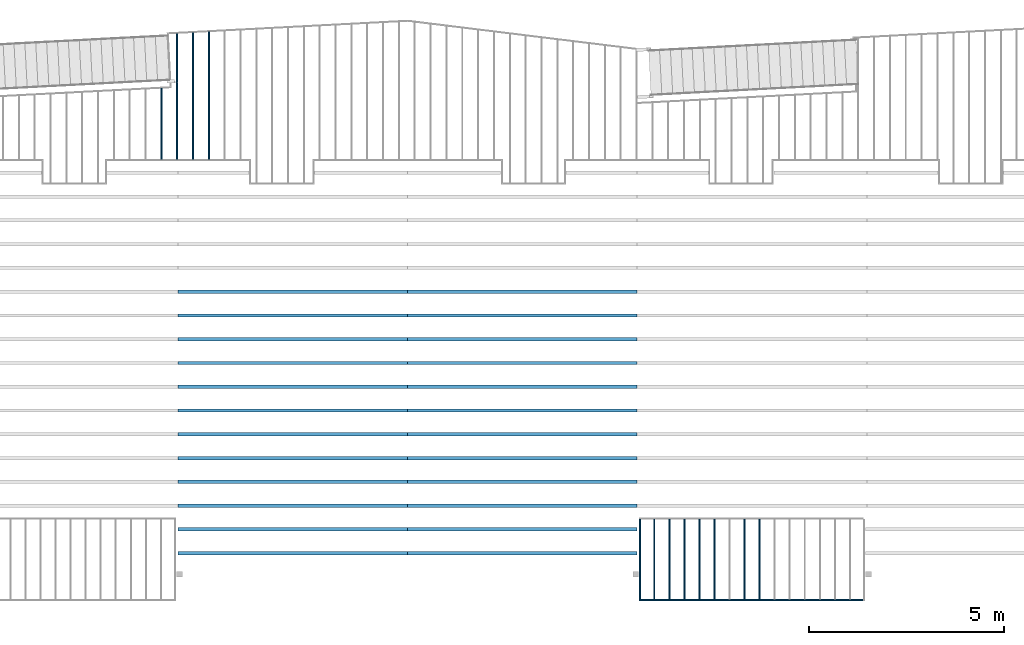
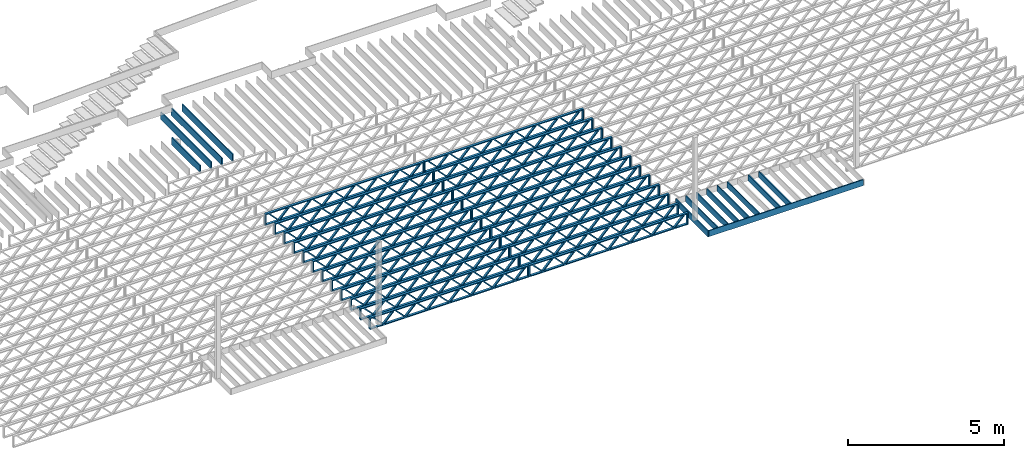
# One storey, part 6 of 23: 37 beams, 4 elements without a shape of their own.
"""IFC4 building model written with IfcOpenShell, lengths in feet."""

from ifc_helpers import new_model, entity, si_unit, converted_unit, derived_unit, direction, frame, frame_2d, origin, origin_2d_with_axis, place, context, subcontext, project, spatial, rectangle, extrude, source, transform, mapped, material, material_profile, profile_set, profile_usage, type_object, type_shapes, element, aggregate, save


model = new_model("IFC4")

# Units and contexts
model_context = context("Model", 3, precision=0.0001, world=origin(), true_north=direction((6.12303176911189e-17, 1.0)))
body_context = subcontext(model_context, "Body", "Model", "MODEL_VIEW")
ifc_project = project(units=[converted_unit("LENGTHUNIT", "FOOT", entity("IfcRatioMeasure", 0.3048), si_unit("LENGTHUNIT", "METRE"), dimensions=[1, 0, 0, 0, 0, 0, 0]), converted_unit("AREAUNIT", "SQUARE FOOT", entity("IfcRatioMeasure", 0.09290304), si_unit("AREAUNIT", "SQUARE_METRE"), dimensions=[2, 0, 0, 0, 0, 0, 0]), converted_unit("VOLUMEUNIT", "CUBIC FOOT", entity("IfcRatioMeasure", 0.028316846592), si_unit("VOLUMEUNIT", "CUBIC_METRE"), dimensions=[3, 0, 0, 0, 0, 0, 0]), converted_unit("PLANEANGLEUNIT", "DEGREE", entity("IfcRatioMeasure", 0.0174532925199433), si_unit("PLANEANGLEUNIT", "RADIAN"), dimensions=[0, 0, 0, 0, 0, 0, 0]), si_unit("MASSUNIT", "GRAM", prefix="KILO"), derived_unit("MASSDENSITYUNIT", [(si_unit("MASSUNIT", "GRAM", prefix="KILO"), 1), (si_unit("LENGTHUNIT", "METRE"), -3)]), derived_unit("MOMENTOFINERTIAUNIT", [(si_unit("LENGTHUNIT", "METRE"), 4)]), si_unit("TIMEUNIT", "SECOND"), si_unit("FREQUENCYUNIT", "HERTZ"), si_unit("THERMODYNAMICTEMPERATUREUNIT", "DEGREE_CELSIUS"), derived_unit("THERMALTRANSMITTANCEUNIT", [(si_unit("MASSUNIT", "GRAM", prefix="KILO"), 1), (si_unit("THERMODYNAMICTEMPERATUREUNIT", "KELVIN"), -1), (si_unit("TIMEUNIT", "SECOND"), -3)]), derived_unit("VOLUMETRICFLOWRATEUNIT", [(si_unit("LENGTHUNIT", "METRE"), 3), (si_unit("TIMEUNIT", "SECOND"), -1)]), si_unit("ELECTRICCURRENTUNIT", "AMPERE"), si_unit("ELECTRICVOLTAGEUNIT", "VOLT"), si_unit("POWERUNIT", "WATT"), si_unit("FORCEUNIT", "NEWTON"), si_unit("ILLUMINANCEUNIT", "LUX"), si_unit("LUMINOUSFLUXUNIT", "LUMEN"), si_unit("LUMINOUSINTENSITYUNIT", "CANDELA"), derived_unit("USERDEFINED", [(si_unit("MASSUNIT", "GRAM", prefix="KILO"), -1), (si_unit("LENGTHUNIT", "METRE"), -2), (si_unit("TIMEUNIT", "SECOND"), 3), (si_unit("LUMINOUSFLUXUNIT", "LUMEN"), 1)]), derived_unit("LINEARVELOCITYUNIT", [(si_unit("LENGTHUNIT", "METRE"), 1), (si_unit("TIMEUNIT", "SECOND"), -1)]), si_unit("PRESSUREUNIT", "PASCAL"), derived_unit("USERDEFINED", [(si_unit("LENGTHUNIT", "METRE"), -2), (si_unit("MASSUNIT", "GRAM", prefix="KILO"), 1), (si_unit("TIMEUNIT", "SECOND"), -2)]), derived_unit("LINEARFORCEUNIT", [(si_unit("MASSUNIT", "GRAM", prefix="KILO"), 1), (si_unit("LENGTHUNIT", "METRE"), 1), (si_unit("TIMEUNIT", "SECOND"), -2), (si_unit("LENGTHUNIT", "METRE"), -1)]), derived_unit("PLANARFORCEUNIT", [(si_unit("MASSUNIT", "GRAM", prefix="KILO"), 1), (si_unit("LENGTHUNIT", "METRE"), 1), (si_unit("TIMEUNIT", "SECOND"), -2), (si_unit("LENGTHUNIT", "METRE"), -2)])], contexts=[model_context])

# Site, building, storey
site_placement = place(None, origin())
site = spatial("IfcSite", under=ifc_project, at=site_placement, CompositionType="ELEMENT")
building_placement = place(site_placement, origin())
building = spatial("IfcBuilding", under=site, at=building_placement, CompositionType="ELEMENT")
storey_placement = place(building_placement, frame((0.0, 0.0, 10.8020833333333)))
storey = spatial("IfcBuildingStorey", under=building, at=storey_placement, Name="2ND FLOOR", CompositionType="ELEMENT", Elevation=10.8020833333333)

# Assembly, beams
assembly_1_placement = place(storey_placement, origin())
assembly_1 = element("IfcElementAssembly", 1, at=assembly_1_placement, inside=storey, Name="Structural Beam System:Structural Framing System", ObjectType="Structural Beam System:Structural Framing System", AssemblyPlace="NOTDEFINED", PredefinedType="BEAM_GRID")
ifc_material_1 = material(Category="Materials")
ifc_material_profile_1 = material_profile(ifc_material_1, rectangle(XDim=0.770833333333333, YDim=0.124999999999994, at=frame_2d((-5.55111512312578e-17, 0.0), x_axis=(1.0, 0.0))))
ifc_profile_set_1 = profile_set([ifc_material_profile_1])
ifc_profile_usage_1 = profile_usage(ifc_profile_set_1, cardinal=8)
beam_type_1 = type_object("IfcBeamType", PredefinedType="BEAM", material=ifc_profile_set_1)
shared_shape_1 = source(origin(), body_context, "Body", "SweptSolid", [
    extrude(rectangle(XDim=0.770833333333333, YDim=0.124999999999994, at=frame_2d((-5.55111512312578e-17, 0.0), x_axis=(1.0, 0.0))), frame((-3.35416666666737, 0.0, 0.0), z_axis=(1.0, 0.0, 0.0), x_axis=(0.0, 0.0, -1.0)), (0.0, 0.0, 1.0), 6.70833333333462),
])
type_shapes(beam_type_1, [shared_shape_1])
beam_1_placement = place(assembly_1_placement, frame((-173.43642510598, 925.341101549317, -0.645833333333471), z_axis=(0.0, 0.0, 1.0), x_axis=(0.0, 1.0, 0.0)))
beam_1 = element("IfcBeam", 2, at=beam_1_placement, type_object=beam_type_1, material=ifc_profile_usage_1, PredefinedType="BEAM", context=body_context, shape_type="MappedRepresentation", body=[
    mapped(shared_shape_1, transform((0.0, 0.0, 0.0), scale=1.0)),
])
ifc_profile_usage_2 = profile_usage(ifc_profile_set_1, cardinal=8)
beam_2_placement = place(assembly_1_placement, frame((-174.703308786538, 925.341101549318, -0.645833333333433), z_axis=(0.0, 0.0, 1.0), x_axis=(0.0, 1.0, 0.0)))
beam_2 = element("IfcBeam", 3, at=beam_2_placement, type_object=beam_type_1, material=ifc_profile_usage_2, PredefinedType="BEAM", context=body_context, shape_type="MappedRepresentation", body=[
    mapped(shared_shape_1, transform((0.0, 0.0, 0.0), scale=1.0)),
])
ifc_profile_usage_3 = profile_usage(ifc_profile_set_1, cardinal=8)
beam_3_placement = place(assembly_1_placement, frame((-177.237076147655, 925.341101549318, -0.645833333333471), z_axis=(0.0, 0.0, 1.0), x_axis=(0.0, 1.0, 0.0)))
beam_3 = element("IfcBeam", 4, at=beam_3_placement, type_object=beam_type_1, material=ifc_profile_usage_3, PredefinedType="BEAM", context=body_context, shape_type="MappedRepresentation", body=[
    mapped(shared_shape_1, transform((0.0, 0.0, 0.0), scale=1.0)),
])
ifc_profile_usage_4 = profile_usage(ifc_profile_set_1, cardinal=8)
beam_4_placement = place(assembly_1_placement, frame((-178.503959828213, 925.341101549318, -0.645833333333471), z_axis=(0.0, 0.0, 1.0), x_axis=(0.0, 1.0, 0.0)))
beam_4 = element("IfcBeam", 5, at=beam_4_placement, type_object=beam_type_1, material=ifc_profile_usage_4, PredefinedType="BEAM", context=body_context, shape_type="MappedRepresentation", body=[
    mapped(shared_shape_1, transform((0.0, 0.0, 0.0), scale=1.0)),
])
ifc_profile_usage_5 = profile_usage(ifc_profile_set_1, cardinal=8)
beam_5_placement = place(assembly_1_placement, frame((-179.770843508771, 925.341101549318, -0.645833333333471), z_axis=(0.0, 0.0, 1.0), x_axis=(0.0, 1.0, 0.0)))
beam_5 = element("IfcBeam", 6, at=beam_5_placement, type_object=beam_type_1, material=ifc_profile_usage_5, PredefinedType="BEAM", context=body_context, shape_type="MappedRepresentation", body=[
    mapped(shared_shape_1, transform((0.0, 0.0, 0.0), scale=1.0)),
])
ifc_profile_usage_6 = profile_usage(ifc_profile_set_1, cardinal=8)
beam_6_placement = place(assembly_1_placement, frame((-181.03772718933, 925.341101549318, -0.645833333333471), z_axis=(0.0, 0.0, 1.0), x_axis=(0.0, 1.0, 0.0)))
beam_6 = element("IfcBeam", 7, at=beam_6_placement, type_object=beam_type_1, material=ifc_profile_usage_6, PredefinedType="BEAM", context=body_context, shape_type="MappedRepresentation", body=[
    mapped(shared_shape_1, transform((0.0, 0.0, 0.0), scale=1.0)),
])
ifc_profile_usage_7 = profile_usage(ifc_profile_set_1, cardinal=8)
beam_7_placement = place(assembly_1_placement, frame((-182.304610869888, 925.341101549319, -0.645833333333471), z_axis=(0.0, 0.0, 1.0), x_axis=(0.0, 1.0, 0.0)))
beam_7 = element("IfcBeam", 8, at=beam_7_placement, type_object=beam_type_1, material=ifc_profile_usage_7, PredefinedType="BEAM", context=body_context, shape_type="MappedRepresentation", body=[
    mapped(shared_shape_1, transform((0.0, 0.0, 0.0), scale=1.0)),
])
aggregate(assembly_1, [beam_1, beam_2, beam_3, beam_4, beam_5, beam_6, beam_7])

assembly_2_placement = place(storey_placement, origin())
assembly_2 = element("IfcElementAssembly", 9, at=assembly_2_placement, inside=storey, Name="Structural Beam System:Structural Framing System", ObjectType="Structural Beam System:Structural Framing System", AssemblyPlace="NOTDEFINED", PredefinedType="BEAM_GRID")
ifc_material_2 = material(Name="WOOD TRUSS", Category="Materials")
ifc_material_profile_2 = material_profile(ifc_material_2, rectangle(XDim=1.73473973950632, YDim=0.125, at=frame_2d((-1.11022302462516e-16, 8.32667268468867e-17), x_axis=(1.0, 0.0))))
ifc_material_profile_3 = material_profile(ifc_material_2, rectangle(XDim=1.73473973950633, YDim=0.125, at=frame_2d((-1.11022302462516e-16, 8.32667268468867e-17), x_axis=(1.0, 0.0))))
ifc_material_profile_4 = material_profile(ifc_material_2, rectangle(XDim=1.73473973950632, YDim=0.125, at=frame_2d((-5.55111512312578e-17, 1.38777878078145e-16), x_axis=(1.0, 0.0))))
ifc_material_profile_5 = material_profile(ifc_material_2, rectangle(XDim=1.73473973950633, YDim=0.125, at=frame_2d((-1.11022302462516e-16, 8.32667268468867e-17), x_axis=(1.0, 0.0))))
ifc_material_profile_6 = material_profile(ifc_material_2, rectangle(XDim=1.73473973950632, YDim=0.125, at=frame_2d((-1.11022302462516e-16, 8.32667268468867e-17), x_axis=(1.0, 0.0))))
ifc_material_profile_7 = material_profile(ifc_material_2, rectangle(XDim=1.73473973950633, YDim=0.125, at=frame_2d((-2.77555756156289e-16, 3.05311331771918e-16), x_axis=(1.0, 0.0))))
ifc_material_profile_8 = material_profile(ifc_material_2, rectangle(XDim=1.73473973950632, YDim=0.124999999999999, at=frame_2d((-3.88578058618805e-16, -2.4980018054066e-16), x_axis=(1.0, 0.0))))
ifc_material_profile_9 = material_profile(ifc_material_2, rectangle(XDim=1.73473973950633, YDim=0.125, at=frame_2d((2.77555756156289e-16, -3.05311331771918e-16), x_axis=(1.0, 0.0))))
ifc_material_profile_10 = material_profile(ifc_material_2, rectangle(XDim=1.73473973950632, YDim=0.124999999999999, at=frame_2d((-1.11022302462516e-16, 8.32667268468867e-17), x_axis=(1.0, 0.0))))
ifc_material_profile_11 = material_profile(ifc_material_2, rectangle(XDim=1.73473973950633, YDim=0.125, at=origin_2d_with_axis()))
ifc_material_profile_12 = material_profile(ifc_material_2, rectangle(XDim=0.124999999999982, YDim=0.291666666666668, at=origin_2d_with_axis()))
ifc_material_profile_13 = material_profile(ifc_material_2, rectangle(XDim=0.124999999999932, YDim=0.291666666666664, at=origin_2d_with_axis()))
ifc_material_profile_14 = material_profile(ifc_material_2, rectangle(XDim=1.25000000000002, YDim=0.29166666666667, at=origin_2d_with_axis()))
ifc_material_profile_15 = material_profile(ifc_material_2, rectangle(XDim=1.25000000000004, YDim=0.291666666666667, at=origin_2d_with_axis()))
ifc_profile_set_2 = profile_set([ifc_material_profile_2, ifc_material_profile_3, ifc_material_profile_4, ifc_material_profile_5, ifc_material_profile_6, ifc_material_profile_7, ifc_material_profile_8, ifc_material_profile_9, ifc_material_profile_10, ifc_material_profile_11, ifc_material_profile_12, ifc_material_profile_13, ifc_material_profile_14, ifc_material_profile_15])
ifc_profile_usage_8 = profile_usage(ifc_profile_set_2, cardinal=8)
beam_type_2 = type_object("IfcBeamType", PredefinedType="BEAM", material=ifc_profile_set_2)
shared_shape_2 = source(origin(), body_context, "Body", "SweptSolid", [
    extrude(rectangle(XDim=1.73473973950632, YDim=0.124999999999999, at=frame_2d((5.55111512312578e-16, 7.21644966006352e-16), x_axis=(1.0, 0.0))), frame((5.95847627016997, -0.145833333333334, 0.0), z_axis=(0.0, 1.0, 0.0), x_axis=(0.693383046997606, 0.0, 0.720569184836762)), (0.0, 0.0, 1.0), 0.291666666666667),
    extrude(rectangle(XDim=1.73473973950633, YDim=0.125, at=origin_2d_with_axis()), frame((4.7081903964967, -0.145833333333334, 0.0), z_axis=(0.0, 1.0, 0.0), x_axis=(0.69338304699761, 0.0, -0.720569184836758)), (0.0, 0.0, 1.0), 0.291666666666666),
    extrude(rectangle(XDim=1.73473973950632, YDim=0.125, at=frame_2d((2.22044604925031e-16, 3.88578058618805e-16), x_axis=(1.0, 0.0))), frame((3.29180960350347, -0.145833333333334, 0.0), z_axis=(0.0, 1.0, 0.0), x_axis=(0.693383046997606, 0.0, 0.720569184836762)), (0.0, 0.0, 1.0), 0.291666666666667),
    extrude(rectangle(XDim=1.73473973950633, YDim=0.125, at=frame_2d((1.11022302462516e-16, -8.32667268468867e-17), x_axis=(1.0, 0.0))), frame((2.0415237298302, -0.145833333333334, 0.0), z_axis=(0.0, 1.0, 0.0), x_axis=(0.69338304699761, 0.0, -0.720569184836758)), (0.0, 0.0, 1.0), 0.291666666666667),
    extrude(rectangle(XDim=1.73473973950632, YDim=0.125, at=frame_2d((-5.55111512312578e-17, 1.38777878078145e-16), x_axis=(1.0, 0.0))), frame((0.625142936836964, -0.145833333333334, 0.0), z_axis=(0.0, 1.0, 0.0), x_axis=(0.693383046997606, 0.0, 0.720569184836762)), (0.0, 0.0, 1.0), 0.291666666666667),
    extrude(rectangle(XDim=1.73473973950633, YDim=0.125, at=frame_2d((-1.11022302462516e-16, 8.32667268468867e-17), x_axis=(1.0, 0.0))), frame((-0.625142936836306, -0.145833333333334, 0.0), z_axis=(0.0, 1.0, 0.0), x_axis=(0.69338304699761, 0.0, -0.720569184836758)), (0.0, 0.0, 1.0), 0.291666666666667),
    extrude(rectangle(XDim=1.73473973950632, YDim=0.125, at=frame_2d((-1.11022302462516e-16, 8.32667268468867e-17), x_axis=(1.0, 0.0))), frame((-2.04152372982954, -0.145833333333334, 0.0), z_axis=(0.0, 1.0, 0.0), x_axis=(0.693383046997606, 0.0, 0.720569184836762)), (0.0, 0.0, 1.0), 0.291666666666667),
    extrude(rectangle(XDim=1.73473973950633, YDim=0.125, at=origin_2d_with_axis()), frame((-3.29180960350281, -0.145833333333334, 0.0), z_axis=(0.0, 1.0, 0.0), x_axis=(0.69338304699761, 0.0, -0.720569184836758)), (0.0, 0.0, 1.0), 0.291666666666667),
    extrude(rectangle(XDim=1.73473973950632, YDim=0.124999999999999, at=frame_2d((-1.11022302462516e-16, 8.32667268468867e-17), x_axis=(1.0, 0.0))), frame((-4.70819039649604, -0.145833333333334, 0.0), z_axis=(0.0, 1.0, 0.0), x_axis=(0.693383046997606, 0.0, 0.720569184836762)), (0.0, 0.0, 1.0), 0.291666666666667),
    extrude(rectangle(XDim=1.73473973950633, YDim=0.125, at=frame_2d((-5.55111512312578e-16, 6.38378239159465e-16), x_axis=(1.0, 0.0))), frame((-5.95847627016931, -0.145833333333334, 0.0), z_axis=(0.0, 1.0, 0.0), x_axis=(0.69338304699761, 0.0, -0.720569184836758)), (0.0, 0.0, 1.0), 0.291666666666666),
    extrude(rectangle(XDim=1.73473973950632, YDim=0.125, at=frame_2d((-7.21644966006352e-16, -5.82867087928207e-16), x_axis=(1.0, 0.0))), frame((8.62514293683647, -0.145833333333334, 0.0), z_axis=(0.0, 1.0, 0.0), x_axis=(0.693383046997607, 0.0, 0.720569184836761)), (0.0, 0.0, 1.0), 0.291666666666667),
    extrude(rectangle(XDim=1.73473973950633, YDim=0.125, at=origin_2d_with_axis()), frame((7.3748570631632, -0.145833333333334, 0.0), z_axis=(0.0, 1.0, 0.0), x_axis=(0.69338304699761, 0.0, -0.720569184836758)), (0.0, 0.0, 1.0), 0.291666666666666),
    extrude(rectangle(XDim=1.73473973950632, YDim=0.124999999999999, at=frame_2d((-1.11022302462516e-16, 8.32667268468867e-17), x_axis=(1.0, 0.0))), frame((-7.37485706316255, -0.145833333333334, 0.0), z_axis=(0.0, 1.0, 0.0), x_axis=(0.693383046997606, 0.0, 0.720569184836762)), (0.0, 0.0, 1.0), 0.291666666666667),
    extrude(rectangle(XDim=1.73473973950633, YDim=0.125, at=origin_2d_with_axis()), frame((-8.62514293683582, -0.145833333333334, 0.0), z_axis=(0.0, 1.0, 0.0), x_axis=(0.69338304699761, 0.0, -0.720569184836758)), (0.0, 0.0, 1.0), 0.291666666666666),
    extrude(rectangle(XDim=0.124999999999982, YDim=0.291666666666668, at=origin_2d_with_axis()), frame((-9.66666666666609, 0.0, 0.687500000000054), z_axis=(1.0, 0.0, 0.0), x_axis=(0.0, 0.0, -1.0)), (0.0, 0.0, 1.0), 19.3333333333322),
    extrude(rectangle(XDim=0.124999999999932, YDim=0.291666666666664, at=origin_2d_with_axis()), frame((-9.66666666666588, 0.0, -0.687499999999984), z_axis=(1.0, 0.0, 0.0), x_axis=(0.0, 0.0, -1.0)), (0.0, 0.0, 1.0), 19.333333333332),
    extrude(rectangle(XDim=1.25000000000002, YDim=0.29166666666667, at=origin_2d_with_axis()), frame((9.54166666666607, 0.0, 0.0), z_axis=(1.0, 0.0, 0.0), x_axis=(0.0, 0.0, -1.0)), (0.0, 0.0, 1.0), 0.12500000000002),
    extrude(rectangle(XDim=1.25000000000004, YDim=0.291666666666667, at=origin_2d_with_axis()), frame((-9.66666666666609, 0.0, 0.0), z_axis=(1.0, 0.0, 0.0), x_axis=(0.0, 0.0, -1.0)), (0.0, 0.0, 1.0), 0.125000000000023),
])
type_shapes(beam_type_2, [shared_shape_2])
beam_8_placement = place(assembly_2_placement, frame((-193.404827152229, 947.861934882651, -0.947916666666881)))
beam_8 = element("IfcBeam", 10, at=beam_8_placement, type_object=beam_type_2, material=ifc_profile_usage_8, PredefinedType="BEAM", context=body_context, shape_type="MappedRepresentation", body=[
    mapped(shared_shape_2, transform((0.0, 0.0, 0.0), scale=1.0)),
])
ifc_profile_usage_9 = profile_usage(ifc_profile_set_2, cardinal=8)
beam_9_placement = place(assembly_2_placement, frame((-193.404827152229, 945.861934882651, -0.947916666666881)))
beam_9 = element("IfcBeam", 11, at=beam_9_placement, type_object=beam_type_2, material=ifc_profile_usage_9, PredefinedType="BEAM", context=body_context, shape_type="MappedRepresentation", body=[
    mapped(shared_shape_2, transform((0.0, 0.0, 0.0), scale=1.0)),
])
ifc_profile_usage_10 = profile_usage(ifc_profile_set_2, cardinal=8)
beam_10_placement = place(assembly_2_placement, frame((-193.404827152229, 943.861934882651, -0.947916666666881)))
beam_10 = element("IfcBeam", 12, at=beam_10_placement, type_object=beam_type_2, material=ifc_profile_usage_10, PredefinedType="BEAM", context=body_context, shape_type="MappedRepresentation", body=[
    mapped(shared_shape_2, transform((0.0, 0.0, 0.0), scale=1.0)),
])
ifc_profile_usage_11 = profile_usage(ifc_profile_set_2, cardinal=8)
beam_11_placement = place(assembly_2_placement, frame((-193.404827152229, 941.861934882651, -0.947916666666881)))
beam_11 = element("IfcBeam", 13, at=beam_11_placement, type_object=beam_type_2, material=ifc_profile_usage_11, PredefinedType="BEAM", context=body_context, shape_type="MappedRepresentation", body=[
    mapped(shared_shape_2, transform((0.0, 0.0, 0.0), scale=1.0)),
])
ifc_profile_usage_12 = profile_usage(ifc_profile_set_2, cardinal=8)
beam_12_placement = place(assembly_2_placement, frame((-193.404827152229, 939.861934882651, -0.947916666666881)))
beam_12 = element("IfcBeam", 14, at=beam_12_placement, type_object=beam_type_2, material=ifc_profile_usage_12, PredefinedType="BEAM", context=body_context, shape_type="MappedRepresentation", body=[
    mapped(shared_shape_2, transform((0.0, 0.0, 0.0), scale=1.0)),
])
ifc_profile_usage_13 = profile_usage(ifc_profile_set_2, cardinal=8)
beam_13_placement = place(assembly_2_placement, frame((-193.404827152229, 937.861934882651, -0.947916666666881)))
beam_13 = element("IfcBeam", 15, at=beam_13_placement, type_object=beam_type_2, material=ifc_profile_usage_13, PredefinedType="BEAM", context=body_context, shape_type="MappedRepresentation", body=[
    mapped(shared_shape_2, transform((0.0, 0.0, 0.0), scale=1.0)),
])
ifc_profile_usage_14 = profile_usage(ifc_profile_set_2, cardinal=8)
beam_14_placement = place(assembly_2_placement, frame((-193.404827152229, 935.861934882651, -0.947916666666881)))
beam_14 = element("IfcBeam", 16, at=beam_14_placement, type_object=beam_type_2, material=ifc_profile_usage_14, PredefinedType="BEAM", context=body_context, shape_type="MappedRepresentation", body=[
    mapped(shared_shape_2, transform((0.0, 0.0, 0.0), scale=1.0)),
])
ifc_profile_usage_15 = profile_usage(ifc_profile_set_2, cardinal=8)
beam_15_placement = place(assembly_2_placement, frame((-193.404827152229, 933.861934882651, -0.947916666666881)))
beam_15 = element("IfcBeam", 17, at=beam_15_placement, type_object=beam_type_2, material=ifc_profile_usage_15, PredefinedType="BEAM", context=body_context, shape_type="MappedRepresentation", body=[
    mapped(shared_shape_2, transform((0.0, 0.0, 0.0), scale=1.0)),
])
ifc_profile_usage_16 = profile_usage(ifc_profile_set_2, cardinal=8)
beam_16_placement = place(assembly_2_placement, frame((-193.404827152229, 931.861934882651, -0.947916666666881)))
beam_16 = element("IfcBeam", 18, at=beam_16_placement, type_object=beam_type_2, material=ifc_profile_usage_16, PredefinedType="BEAM", context=body_context, shape_type="MappedRepresentation", body=[
    mapped(shared_shape_2, transform((0.0, 0.0, 0.0), scale=1.0)),
])
ifc_profile_usage_17 = profile_usage(ifc_profile_set_2, cardinal=8)
beam_17_placement = place(assembly_2_placement, frame((-193.404827152229, 929.861934882651, -0.947916666666881)))
beam_17 = element("IfcBeam", 19, at=beam_17_placement, type_object=beam_type_2, material=ifc_profile_usage_17, PredefinedType="BEAM", context=body_context, shape_type="MappedRepresentation", body=[
    mapped(shared_shape_2, transform((0.0, 0.0, 0.0), scale=1.0)),
])
ifc_profile_usage_18 = profile_usage(ifc_profile_set_2, cardinal=8)
beam_18_placement = place(assembly_2_placement, frame((-193.404827152229, 927.861934882651, -0.947916666666881)))
beam_18 = element("IfcBeam", 20, at=beam_18_placement, type_object=beam_type_2, material=ifc_profile_usage_18, PredefinedType="BEAM", context=body_context, shape_type="MappedRepresentation", body=[
    mapped(shared_shape_2, transform((0.0, 0.0, 0.0), scale=1.0)),
])
ifc_profile_usage_19 = profile_usage(ifc_profile_set_2, cardinal=8)
beam_19_placement = place(assembly_2_placement, frame((-193.404827152229, 925.861934882651, -0.947916666666881)))
beam_19 = element("IfcBeam", 21, at=beam_19_placement, type_object=beam_type_2, material=ifc_profile_usage_19, PredefinedType="BEAM", context=body_context, shape_type="MappedRepresentation", body=[
    mapped(shared_shape_2, transform((0.0, 0.0, 0.0), scale=1.0)),
])
aggregate(assembly_2, [beam_8, beam_9, beam_10, beam_11, beam_12, beam_13, beam_14, beam_15, beam_16, beam_17, beam_18, beam_19])

assembly_3_placement = place(storey_placement, origin())
assembly_3 = element("IfcElementAssembly", 22, at=assembly_3_placement, inside=storey, Name="Structural Beam System:Structural Framing System", ObjectType="Structural Beam System:Structural Framing System", AssemblyPlace="NOTDEFINED", PredefinedType="BEAM_GRID")
ifc_profile_usage_20 = profile_usage(ifc_profile_set_2, cardinal=8)
beam_20_placement = place(assembly_3_placement, frame((-212.738160485495, 947.861934882651, -0.947916666666881), z_axis=(0.0, 0.0, 1.0), x_axis=(-1.0, 0.0, 0.0)))
beam_20 = element("IfcBeam", 23, at=beam_20_placement, type_object=beam_type_2, material=ifc_profile_usage_20, PredefinedType="BEAM", context=body_context, shape_type="MappedRepresentation", body=[
    mapped(shared_shape_2, transform((0.0, 0.0, 0.0), scale=1.0)),
])
ifc_profile_usage_21 = profile_usage(ifc_profile_set_2, cardinal=8)
beam_21_placement = place(assembly_3_placement, frame((-212.738160485495, 945.861934882651, -0.947916666666881), z_axis=(0.0, 0.0, 1.0), x_axis=(-1.0, 0.0, 0.0)))
beam_21 = element("IfcBeam", 24, at=beam_21_placement, type_object=beam_type_2, material=ifc_profile_usage_21, PredefinedType="BEAM", context=body_context, shape_type="MappedRepresentation", body=[
    mapped(shared_shape_2, transform((0.0, 0.0, 0.0), scale=1.0)),
])
ifc_profile_usage_22 = profile_usage(ifc_profile_set_2, cardinal=8)
beam_22_placement = place(assembly_3_placement, frame((-212.738160485495, 943.861934882651, -0.947916666666881), z_axis=(0.0, 0.0, 1.0), x_axis=(-1.0, 0.0, 0.0)))
beam_22 = element("IfcBeam", 25, at=beam_22_placement, type_object=beam_type_2, material=ifc_profile_usage_22, PredefinedType="BEAM", context=body_context, shape_type="MappedRepresentation", body=[
    mapped(shared_shape_2, transform((0.0, 0.0, 0.0), scale=1.0)),
])
ifc_profile_usage_23 = profile_usage(ifc_profile_set_2, cardinal=8)
beam_23_placement = place(assembly_3_placement, frame((-212.738160485495, 941.861934882651, -0.947916666666881), z_axis=(0.0, 0.0, 1.0), x_axis=(-1.0, 0.0, 0.0)))
beam_23 = element("IfcBeam", 26, at=beam_23_placement, type_object=beam_type_2, material=ifc_profile_usage_23, PredefinedType="BEAM", context=body_context, shape_type="MappedRepresentation", body=[
    mapped(shared_shape_2, transform((0.0, 0.0, 0.0), scale=1.0)),
])
ifc_profile_usage_24 = profile_usage(ifc_profile_set_2, cardinal=8)
beam_24_placement = place(assembly_3_placement, frame((-212.738160485495, 939.861934882651, -0.947916666666881), z_axis=(0.0, 0.0, 1.0), x_axis=(-1.0, 0.0, 0.0)))
beam_24 = element("IfcBeam", 27, at=beam_24_placement, type_object=beam_type_2, material=ifc_profile_usage_24, PredefinedType="BEAM", context=body_context, shape_type="MappedRepresentation", body=[
    mapped(shared_shape_2, transform((0.0, 0.0, 0.0), scale=1.0)),
])
ifc_profile_usage_25 = profile_usage(ifc_profile_set_2, cardinal=8)
beam_25_placement = place(assembly_3_placement, frame((-212.738160485495, 937.861934882651, -0.947916666666881), z_axis=(0.0, 0.0, 1.0), x_axis=(-1.0, 0.0, 0.0)))
beam_25 = element("IfcBeam", 28, at=beam_25_placement, type_object=beam_type_2, material=ifc_profile_usage_25, PredefinedType="BEAM", context=body_context, shape_type="MappedRepresentation", body=[
    mapped(shared_shape_2, transform((0.0, 0.0, 0.0), scale=1.0)),
])
ifc_profile_usage_26 = profile_usage(ifc_profile_set_2, cardinal=8)
beam_26_placement = place(assembly_3_placement, frame((-212.738160485495, 935.861934882651, -0.947916666666881), z_axis=(0.0, 0.0, 1.0), x_axis=(-1.0, 0.0, 0.0)))
beam_26 = element("IfcBeam", 29, at=beam_26_placement, type_object=beam_type_2, material=ifc_profile_usage_26, PredefinedType="BEAM", context=body_context, shape_type="MappedRepresentation", body=[
    mapped(shared_shape_2, transform((0.0, 0.0, 0.0), scale=1.0)),
])
ifc_profile_usage_27 = profile_usage(ifc_profile_set_2, cardinal=8)
beam_27_placement = place(assembly_3_placement, frame((-212.738160485495, 933.861934882651, -0.947916666666881), z_axis=(0.0, 0.0, 1.0), x_axis=(-1.0, 0.0, 0.0)))
beam_27 = element("IfcBeam", 30, at=beam_27_placement, type_object=beam_type_2, material=ifc_profile_usage_27, PredefinedType="BEAM", context=body_context, shape_type="MappedRepresentation", body=[
    mapped(shared_shape_2, transform((0.0, 0.0, 0.0), scale=1.0)),
])
ifc_profile_usage_28 = profile_usage(ifc_profile_set_2, cardinal=8)
beam_28_placement = place(assembly_3_placement, frame((-212.738160485495, 931.861934882651, -0.947916666666881), z_axis=(0.0, 0.0, 1.0), x_axis=(-1.0, 0.0, 0.0)))
beam_28 = element("IfcBeam", 31, at=beam_28_placement, type_object=beam_type_2, material=ifc_profile_usage_28, PredefinedType="BEAM", context=body_context, shape_type="MappedRepresentation", body=[
    mapped(shared_shape_2, transform((0.0, 0.0, 0.0), scale=1.0)),
])
ifc_profile_usage_29 = profile_usage(ifc_profile_set_2, cardinal=8)
beam_29_placement = place(assembly_3_placement, frame((-212.738160485495, 929.861934882651, -0.947916666666881), z_axis=(0.0, 0.0, 1.0), x_axis=(-1.0, 0.0, 0.0)))
beam_29 = element("IfcBeam", 32, at=beam_29_placement, type_object=beam_type_2, material=ifc_profile_usage_29, PredefinedType="BEAM", context=body_context, shape_type="MappedRepresentation", body=[
    mapped(shared_shape_2, transform((0.0, 0.0, 0.0), scale=1.0)),
])
ifc_profile_usage_30 = profile_usage(ifc_profile_set_2, cardinal=8)
beam_30_placement = place(assembly_3_placement, frame((-212.738160485495, 927.861934882651, -0.947916666666881), z_axis=(0.0, 0.0, 1.0), x_axis=(-1.0, 0.0, 0.0)))
beam_30 = element("IfcBeam", 33, at=beam_30_placement, type_object=beam_type_2, material=ifc_profile_usage_30, PredefinedType="BEAM", context=body_context, shape_type="MappedRepresentation", body=[
    mapped(shared_shape_2, transform((0.0, 0.0, 0.0), scale=1.0)),
])
ifc_profile_usage_31 = profile_usage(ifc_profile_set_2, cardinal=8)
beam_31_placement = place(assembly_3_placement, frame((-212.738160485495, 925.861934882651, -0.947916666666881), z_axis=(0.0, 0.0, 1.0), x_axis=(-1.0, 0.0, 0.0)))
beam_31 = element("IfcBeam", 34, at=beam_31_placement, type_object=beam_type_2, material=ifc_profile_usage_31, PredefinedType="BEAM", context=body_context, shape_type="MappedRepresentation", body=[
    mapped(shared_shape_2, transform((0.0, 0.0, 0.0), scale=1.0)),
])
aggregate(assembly_3, [beam_20, beam_21, beam_22, beam_23, beam_24, beam_25, beam_26, beam_27, beam_28, beam_29, beam_30, beam_31])

assembly_4_placement = place(storey_placement, origin())
assembly_4 = element("IfcElementAssembly", 35, at=assembly_4_placement, inside=storey, Name="Structural Beam System:Structural Framing System", ObjectType="Structural Beam System:Structural Framing System", AssemblyPlace="NOTDEFINED", PredefinedType="BEAM_GRID")
ifc_material_profile_16 = material_profile(ifc_material_1, rectangle(XDim=0.9375, YDim=0.125000000000011, at=origin_2d_with_axis()))
ifc_profile_set_3 = profile_set([ifc_material_profile_16])
ifc_profile_usage_32 = profile_usage(ifc_profile_set_3, cardinal=8)
beam_type_3 = type_object("IfcBeamType", PredefinedType="BEAM", material=ifc_profile_set_3)
shared_shape_3 = source(origin(), body_context, "Body", "SweptSolid", [
    extrude(rectangle(XDim=0.9375, YDim=0.125000000000011, at=origin_2d_with_axis()), frame((-2.97386265030843, 0.0, 0.0), z_axis=(1.0, 0.0, 0.0), x_axis=(0.0, 0.0, -1.0)), (0.0, 0.0, 1.0), 5.94772530061687),
])
type_shapes(beam_type_3, [shared_shape_3])
beam_32_placement = place(assembly_4_placement, frame((-223.800660485462, 962.002466483765, -0.729166666666744), z_axis=(0.0, 0.0, 1.0), x_axis=(0.0, 1.0, 0.0)))
beam_32 = element("IfcBeam", 36, at=beam_32_placement, type_object=beam_type_3, material=ifc_profile_usage_32, PredefinedType="BEAM", context=body_context, shape_type="MappedRepresentation", body=[
    mapped(shared_shape_3, transform((0.0, 0.0, 0.0), scale=1.0)),
])
ifc_profile_usage_33 = profile_usage(ifc_profile_set_3, cardinal=8)
beam_type_4 = type_object("IfcBeamType", PredefinedType="BEAM", material=ifc_profile_set_3)
shared_shape_4 = source(origin(), body_context, "Body", "SweptSolid", [
    extrude(rectangle(XDim=0.9375, YDim=0.125000000000011, at=origin_2d_with_axis()), frame((-5.31404394297266, 0.0, 0.0), z_axis=(1.0, 0.0, 0.0), x_axis=(0.0, 0.0, -1.0)), (0.0, 0.0, 1.0), 10.5622266281151),
])
type_shapes(beam_type_4, [shared_shape_4])
beam_33_placement = place(assembly_4_placement, frame((-222.467327152129, 964.342647459835, -0.729166666666744), z_axis=(0.0, 0.0, 1.0), x_axis=(0.0, 1.0, 0.0)))
beam_33 = element("IfcBeam", 37, at=beam_33_placement, type_object=beam_type_4, material=ifc_profile_usage_33, PredefinedType="BEAM", context=body_context, shape_type="MappedRepresentation", body=[
    mapped(shared_shape_4, transform((0.0, 0.0, 0.0), scale=1.0)),
])
ifc_profile_usage_34 = profile_usage(ifc_profile_set_3, cardinal=8)
beam_type_5 = type_object("IfcBeamType", PredefinedType="BEAM", material=ifc_profile_set_3)
shared_shape_5 = source(origin(), body_context, "Body", "SweptSolid", [
    extrude(rectangle(XDim=0.9375, YDim=0.125000000000011, at=origin_2d_with_axis()), frame((-5.31880329353191, 0.0, 0.0), z_axis=(1.0, 0.0, 0.0), x_axis=(0.0, 0.0, -1.0)), (0.0, 0.0, 1.0), 10.6376065870638),
])
type_shapes(beam_type_5, [shared_shape_5])
beam_34_placement = place(assembly_4_placement, frame((-221.133993818795, 964.3474064934, -0.729166666666744), z_axis=(0.0, 0.0, 1.0), x_axis=(0.0, 1.0, 0.0)))
beam_34 = element("IfcBeam", 38, at=beam_34_placement, type_object=beam_type_5, material=ifc_profile_usage_34, PredefinedType="BEAM", context=body_context, shape_type="MappedRepresentation", body=[
    mapped(shared_shape_5, transform((0.0, 0.0, 0.0), scale=1.0)),
])
ifc_profile_usage_35 = profile_usage(ifc_profile_set_3, cardinal=8)
beam_type_6 = type_object("IfcBeamType", PredefinedType="BEAM", material=ifc_profile_set_3)
shared_shape_6 = source(origin(), body_context, "Body", "SweptSolid", [
    extrude(rectangle(XDim=0.9375, YDim=0.125000000000011, at=origin_2d_with_axis()), frame((-5.35354820779077, 0.0, 0.0), z_axis=(1.0, 0.0, 0.0), x_axis=(0.0, 0.0, -1.0)), (0.0, 0.0, 1.0), 10.7070964155815),
])
type_shapes(beam_type_6, [shared_shape_6])
beam_35_placement = place(assembly_4_placement, frame((-219.800660485462, 964.382151090665, -0.729166666666744), z_axis=(0.0, 0.0, 1.0), x_axis=(0.0, 1.0, 0.0)))
beam_35 = element("IfcBeam", 39, at=beam_35_placement, type_object=beam_type_6, material=ifc_profile_usage_35, PredefinedType="BEAM", context=body_context, shape_type="MappedRepresentation", body=[
    mapped(shared_shape_6, transform((0.0, 0.0, 0.0), scale=1.0)),
])
aggregate(assembly_4, [beam_32, beam_33, beam_34, beam_35])

# Beams
ifc_profile_usage_36 = profile_usage(ifc_profile_set_1, cardinal=8)
beam_type_7 = type_object("IfcBeamType", PredefinedType="BEAM", material=ifc_profile_set_1)
shared_shape_7 = source(origin(), body_context, "Body", "SweptSolid", [
    extrude(rectangle(XDim=0.770833333333333, YDim=0.124999999999994, at=frame_2d((-5.55111512312578e-17, 0.0), x_axis=(1.0, 0.0))), frame((-3.47916666666737, 0.0, 0.0), z_axis=(1.0, 0.0, 0.0), x_axis=(0.0, 0.0, -1.0)), (0.0, 0.0, 1.0), 6.83333333333485),
])
type_shapes(beam_type_7, [shared_shape_7])
beam_36_placement = place(storey_placement, frame((-183.5089915739, 925.341101549319, -0.645833333333512), z_axis=(0.0, 0.0, 1.0), x_axis=(0.0, 1.0, 0.0)))
element("IfcBeam", 40, at=beam_36_placement, inside=storey, type_object=beam_type_7, material=ifc_profile_usage_36, PredefinedType="BEAM", context=body_context, shape_type="MappedRepresentation", body=[
    mapped(shared_shape_7, transform((0.0, 0.0, 0.0), scale=1.0)),
])
ifc_material_3 = material(Name="BRAKE METAL FLASHING AT PERIMETER 2X LEDGER", Category="Materials")
ifc_material_profile_17 = material_profile(ifc_material_3, rectangle(XDim=0.770833333333333, YDim=0.124999999999994, at=frame_2d((-1.11022302462516e-16, 0.0), x_axis=(1.0, 0.0))), Name="BRAKE METAL FLASHING AT PERIMETER 2X LEDGER")
ifc_profile_set_4 = profile_set([ifc_material_profile_17], Name="BRAKE METAL FLASHING AT PERIMETER 2X LEDGER")
ifc_profile_usage_37 = profile_usage(ifc_profile_set_4, cardinal=8)
beam_type_8 = type_object("IfcBeamType", PredefinedType="BEAM", material=ifc_profile_set_4)
shared_shape_8 = source(origin(), body_context, "Body", "SweptSolid", [
    extrude(rectangle(XDim=0.770833333333333, YDim=0.124999999999994, at=frame_2d((-1.11022302462516e-16, 0.0), x_axis=(1.0, 0.0))), frame((-9.37499887751909, 0.0, 0.0), z_axis=(1.0, 0.0, 0.0), x_axis=(0.0, 0.0, -1.0)), (0.0, 0.0, 1.0), 18.7499977550382),
])
type_shapes(beam_type_8, [shared_shape_8])
beam_37_placement = place(storey_placement, frame((-174.071492696381, 921.92443488265, -0.645833333333494)))
element("IfcBeam", 41, at=beam_37_placement, inside=storey, type_object=beam_type_8, material=ifc_profile_usage_37, PredefinedType="BEAM", context=body_context, shape_type="MappedRepresentation", body=[
    mapped(shared_shape_8, transform((0.0, 0.0, 0.0), scale=1.0)),
])

save(model, "model.ifc")
